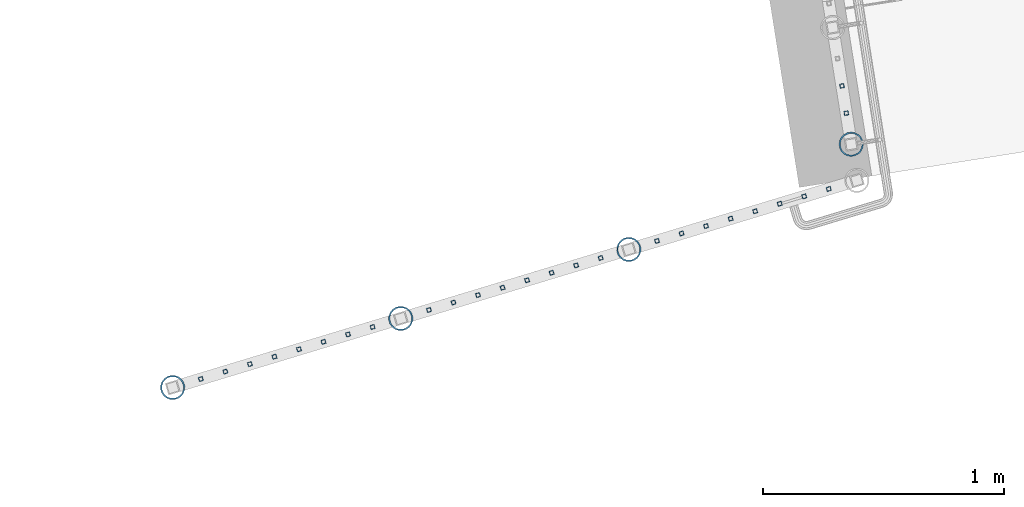
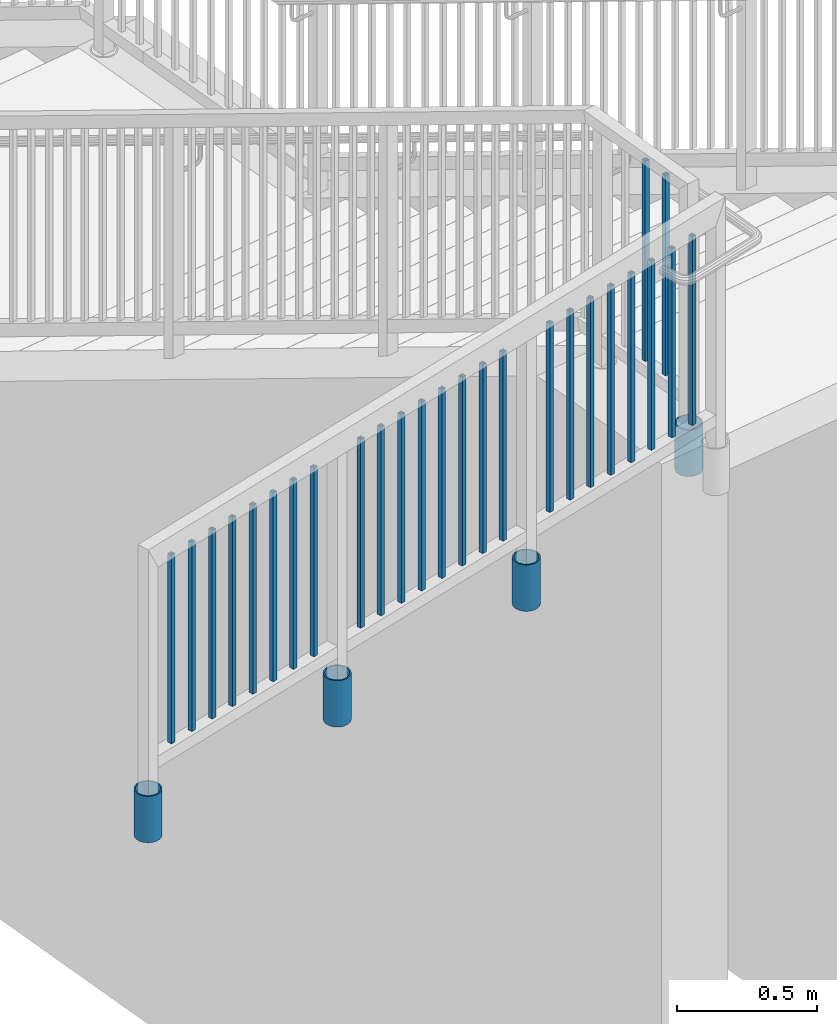
# One storey, part 209 of 975: 30 columns.
"""IFC2X3 building model written with IfcOpenShell, lengths in millimetres."""

from ifc_helpers import new_model, si_unit, frame, origin_with_axes, place, context, subcontext, project, spatial, faceted_brep, material, type_object, element, save


model = new_model("IFC2X3")

# Units and contexts
model_context = context("Model", 3, precision=1e-05, world=origin_with_axes())
body_context = subcontext(model_context, "Body", "Model", "MODEL_VIEW")
ifc_project = project(units=[si_unit("LENGTHUNIT", "METRE", prefix="MILLI"), si_unit("AREAUNIT", "SQUARE_METRE"), si_unit("VOLUMEUNIT", "CUBIC_METRE"), si_unit("MASSUNIT", "GRAM", prefix="KILO"), si_unit("TIMEUNIT", "SECOND"), si_unit("PLANEANGLEUNIT", "RADIAN"), si_unit("SOLIDANGLEUNIT", "STERADIAN"), si_unit("THERMODYNAMICTEMPERATUREUNIT", "DEGREE_CELSIUS"), si_unit("LUMINOUSINTENSITYUNIT", "LUMEN")], contexts=[model_context])

# Site, building, storey
site_placement = place(None, origin_with_axes())
site = spatial("IfcSite", under=ifc_project, at=site_placement, CompositionType="ELEMENT")
building_placement = place(site_placement, origin_with_axes())
building = spatial("IfcBuilding", under=site, at=building_placement, Name="Undefined", CompositionType="ELEMENT")
storey_placement = place(building_placement, origin_with_axes())
storey = spatial("IfcBuildingStorey", under=building, at=storey_placement, Name="Undefined", CompositionType="ELEMENT", Elevation=0.0)

# Columns
ifc_material_1 = material()
column_type_1 = type_object("IfcColumnType", Name="HSS3/4X3/4X.120_TUBES", PredefinedType="NOTDEFINED")
for number, where, z_axis, x_axis, name in (
    (1, (-1494.55040763279, 20040.1609229105, 4178.29999167089), (-0.987688340611262, -0.156434464938429, 0.0), (0.0, 0.0, 1.0), "PICKET"),
    (2, (-1512.5251867995, 20153.6491800454, 4178.29999167089), (-0.987688340611262, -0.156434464938429, 0.0), (0.0, 0.0, 1.0), "PICKET"),
):
    element("IfcColumn", number, at=place(storey_placement, frame(where, z_axis=z_axis, x_axis=x_axis)), inside=storey, type_object=column_type_1, material=ifc_material_1, Name=name, ObjectType="HSS3/4X3/4X.120_TUBES", context=body_context, shape_type="Brep", body=[
        faceted_brep([(0.0, 6.34999999998763, -6.34999999998763), (0.0, -6.35000000000582, -6.34999999998763), (876.3, -6.35000000000218, -6.3500000000131), (876.3, 6.34999999999854, -6.35000000000946), (0.0, -6.34999999998763, 6.34999999998763), (876.3, -6.34999999999854, 6.34999999999127), (0.0, 6.35000000000946, 6.34999999998763), (876.3, 6.35000000000582, 6.34999999999491), (0.0, 9.52499999997963, -9.52499999997963), (0.0, 9.52500000000873, 9.5249999999869), (876.3, 9.52500000000146, 9.52499999999418), (876.3, 9.52499999999782, -9.52500000001237), (0.0, -9.52499999997963, 9.52499999998327), (876.3, -9.52499999999782, 9.52499999999054), (0.0, -9.52500000000873, -9.5249999999869), (876.3, -9.52500000000146, -9.52500000001237)], [[[0, 1, 2, 3]], [[1, 4, 5, 2]], [[4, 6, 7, 5]], [[6, 0, 3, 7]], [[8, 9, 10, 11]], [[9, 12, 13, 10]], [[12, 14, 15, 13]], [[14, 8, 11, 15]], [[13, 15, 11, 10], [5, 7, 3, 2]], [[14, 12, 9, 8], [6, 4, 1, 0]]]),
    ])
for number, where, z_axis, x_axis, name in (
    (3, (-1567.45735962821, 19725.1939051161, 4178.29999683213), (0.957137608769341, 0.289633557930203, -1.36013231895049e-08), (0.0, 0.0, 1.0), "PICKET"),
    (4, (-1669.42828823734, 19694.3326589814, 4178.29999673016), (0.957137608769341, 0.289633557930203, -1.36013231895049e-08), (0.0, 0.0, 1.0), "PICKET"),
    (5, (-1771.39921684648, 19663.4714128468, 4178.29999662819), (0.957137608769341, 0.289633557930203, -1.36013231895049e-08), (0.0, 0.0, 1.0), "PICKET"),
    (6, (-1873.37014545561, 19632.6101667121, 4178.29999652622), (0.957137608769341, 0.289633557930203, -1.36013231895049e-08), (0.0, 0.0, 1.0), "PICKET"),
    (7, (-1975.34107406475, 19601.7489205775, 4178.29999642425), (0.957137608769341, 0.289633557930203, -1.36013231895049e-08), (0.0, 0.0, 1.0), "PICKET"),
    (8, (-2077.31200267388, 19570.8876744428, 4178.29999632228), (0.957137608769341, 0.289633557930203, -1.36013231895049e-08), (0.0, 0.0, 1.0), "PICKET"),
    (9, (-2179.28293128302, 19540.0264283082, 4178.29999622031), (0.957137608769341, 0.289633557930203, -1.36013231895049e-08), (0.0, 0.0, 1.0), "PICKET"),
    (10, (-2281.25385989215, 19509.1651821735, 4178.29999611834), (0.957137608769341, 0.289633557930203, -1.36013231895049e-08), (0.0, 0.0, 1.0), "PICKET"),
    (11, (-2515.58641139511, 19438.2450223992, 4178.30000376634), (0.957137608769341, 0.289633557930203, -1.36013231895049e-08), (0.0, 0.0, 1.0), "PICKET"),
    (12, (-2617.55734000425, 19407.3837762646, 4178.30000366437), (0.957137608769341, 0.289633557930203, -1.36013231895049e-08), (0.0, 0.0, 1.0), "PICKET"),
    (13, (-2719.52826861338, 19376.5225301299, 4178.3000035624), (0.957137608769341, 0.289633557930203, -1.36013231895049e-08), (0.0, 0.0, 1.0), "PICKET"),
    (14, (-2821.49919722252, 19345.6612839953, 4178.30000346042), (0.957137608769341, 0.289633557930203, -1.36013231895049e-08), (0.0, 0.0, 1.0), "PICKET"),
    (15, (-2923.47012583165, 19314.8000378606, 4178.30000335845), (0.957137608769341, 0.289633557930203, -1.36013231895049e-08), (0.0, 0.0, 1.0), "PICKET"),
    (16, (-3025.44105444079, 19283.938791726, 4178.30000325648), (0.957137608769341, 0.289633557930203, -1.36013231895049e-08), (0.0, 0.0, 1.0), "PICKET"),
    (17, (-3127.41198304992, 19253.0775455913, 4178.30000315451), (0.957137608769341, 0.289633557930203, -1.36013231895049e-08), (0.0, 0.0, 1.0), "PICKET"),
    (18, (-3229.38291165906, 19222.2162994567, 4178.30000305254), (0.957137608769341, 0.289633557930203, -1.36013231895049e-08), (0.0, 0.0, 1.0), "PICKET"),
    (19, (-3463.71666416523, 19151.2957762017, 4178.30001070463), (0.957137608769341, 0.289633557930203, -1.36013231895049e-08), (0.0, 0.0, 1.0), "PICKET"),
    (20, (-3565.68759277437, 19120.4345300671, 4178.30001060266), (0.957137608769341, 0.289633557930203, -1.36013231895049e-08), (0.0, 0.0, 1.0), "PICKET"),
    (21, (-3667.6585213835, 19089.5732839324, 4178.30001050068), (0.957137608769341, 0.289633557930203, -1.36013231895049e-08), (0.0, 0.0, 1.0), "PICKET"),
    (22, (-3769.62944999264, 19058.7120377978, 4178.30001039871), (0.957137608769341, 0.289633557930203, -1.36013231895049e-08), (0.0, 0.0, 1.0), "PICKET"),
    (23, (-3871.60037860177, 19027.8507916631, 4178.30001029674), (0.957137608769341, 0.289633557930203, -1.36013231895049e-08), (0.0, 0.0, 1.0), "PICKET"),
    (24, (-3973.57130721091, 18996.9895455285, 4178.30001019477), (0.957137608769341, 0.289633557930203, -1.36013231895049e-08), (0.0, 0.0, 1.0), "PICKET"),
    (25, (-4075.54223582004, 18966.1282993938, 4178.3000100928), (0.957137608769341, 0.289633557930203, -1.36013231895049e-08), (0.0, 0.0, 1.0), "PICKET"),
    (26, (-4177.51316442918, 18935.2670532592, 4178.30000999083), (0.957137608769341, 0.289633557930203, -1.36013231895049e-08), (0.0, 0.0, 1.0), "PICKET"),
):
    element("IfcColumn", number, at=place(storey_placement, frame(where, z_axis=z_axis, x_axis=x_axis)), inside=storey, type_object=column_type_1, material=ifc_material_1, Name=name, ObjectType="HSS3/4X3/4X.120_TUBES", context=body_context, shape_type="Brep", body=[
        faceted_brep([(0.0, 6.34999999998763, -6.34999999998763), (0.0, -6.35000000000582, -6.34999999998763), (825.49997943247, -6.35000000000582, -6.34999999998763), (825.49997943247, 6.34999999998763, -6.34999999998763), (0.0, -6.34999999998763, 6.34999999998763), (825.49997943247, -6.34999999998763, 6.34999999998763), (0.0, 6.35000000000946, 6.34999999998763), (825.49997943247, 6.35000000000946, 6.34999999998763), (0.0, 9.52499999997963, -9.52499999997963), (0.0, 9.52500000000873, 9.5249999999869), (825.49997943247, 9.52500000000873, 9.5249999999869), (825.49997943247, 9.52499999997963, -9.52499999997963), (0.0, -9.52499999997963, 9.52499999998327), (825.49997943247, -9.52499999997963, 9.52499999998327), (0.0, -9.52500000000873, -9.5249999999869), (825.49997943247, -9.52500000000873, -9.5249999999869)], [[[0, 1, 2, 3]], [[1, 4, 5, 2]], [[4, 6, 7, 5]], [[6, 0, 3, 7]], [[8, 9, 10, 11]], [[9, 12, 13, 10]], [[12, 14, 15, 13]], [[14, 8, 11, 15]], [[13, 15, 11, 10], [5, 7, 3, 2]], [[14, 12, 9, 8], [6, 4, 1, 0]]]),
    ])
ifc_material_2 = material(Name="STEEL/A53")
column_type_2 = type_object("IfcColumnType", Name="PIPE3-1/2STD", PredefinedType="NOTDEFINED")
column_1_placement = place(storey_placement, frame((-1474.06692255113, 19910.997122319, 3835.40003518347), z_axis=(-0.587785252279345, -0.809016994384486, -8.09014181868407e-10), x_axis=(0.0, 0.0, 1.0)))
element("IfcColumn", 27, at=column_1_placement, inside=storey, type_object=column_type_2, material=ifc_material_2, ObjectType="PIPE3-1/2STD", context=body_context, shape_type="Brep", body=[
    faceted_brep([(0.0, -45.0595999999932, 1.45519152283669e-11), (0.0, -42.8542262016344, 13.924182159768), (203.199999999991, -42.8542262017145, 13.9241821598171), (203.19999999999, -45.0596000000478, 5.82076609134674e-11), (0.0, -36.45398215971, 26.4853683542424), (203.199999999993, -36.45398215981, 26.4853683542988), (0.0, -26.4853683541623, 36.45398215979), (203.199999999995, -26.4853683542788, 36.4539821598537), (0.0, -13.9241821596988, 42.8542262017108), (203.199999999998, -13.9241821598262, 42.8542262017836), (0.0, 3.63797880709171e-11, 45.0596000000514), (203.2, -9.27684595808387e-11, 45.0596000001387), (0.0, 13.9241821597716, 42.8542262017036), (203.200000000003, 13.9241821596443, 42.8542262017927), (0.0, 26.4853683542242, 36.4539821597718), (203.200000000006, 26.4853683541096, 36.4539821598701), (0.0, 36.4539821597537, 26.4853683542206), (203.200000000008, 36.4539821596554, 26.4853683543224), (0.0, 42.8542262016563, 13.9241821597425), (203.200000000009, 42.8542262015817, 13.9241821598443), (0.0, 45.0595999999932, -1.09139364212751e-11), (203.200000000009, 45.0595999999423, 8.9130480773747e-11), (0.0, 42.8542262016344, -13.9241821597643), (203.200000000008, 42.854226201609, -13.9241821596697), (0.0, 36.45398215971, -26.4853683542387), (203.200000000007, 36.4539821597045, -26.4853683541514), (0.0, 26.4853683541623, -36.4539821597864), (203.200000000004, 26.4853683541733, -36.4539821597064), (0.0, 13.9241821596988, -42.8542262017072), (203.200000000002, 13.9241821597225, -42.8542262016381), (0.0, -3.63797880709171e-11, -45.0596000000478), (203.199999999999, -9.09494701772928e-12, -45.0595999999914), (0.0, -13.9241821597716, -42.8542262016963), (203.199999999996, -13.9241821597479, -42.8542262016472), (0.0, -26.4853683542242, -36.4539821597682), (203.199999999993, -26.4853683542133, -36.4539821597227), (0.0, -36.4539821597537, -26.4853683542169), (203.199999999992, -36.4539821597609, -26.4853683541751), (0.0, -42.8542262016563, -13.9241821597352), (203.199999999991, -42.8542262016872, -13.924182159697), (0.0, -50.799999999992, 1.81898940354586e-11), (0.0, -48.3136710278013, -15.6980633142484), (203.199999999989, -48.313671027825, -15.6980633142139), (203.199999999989, -50.8000000000466, 5.63886715099216e-11), (0.0, -41.0980633142644, -29.8594908164741), (203.19999999999, -41.0980633142663, -29.8594908164414), (0.0, -29.859490816485, -41.0980633142826), (203.199999999993, -29.8594908164687, -41.0980633142426), (0.0, -15.6980633142848, -48.313671027845), (203.199999999995, -15.6980633142539, -48.313671027794), (0.0, -4.36557456851006e-11, -50.8000000000575), (203.199999999998, -7.27595761418343e-12, -50.7999999999993), (0.0, 15.6980633142011, -48.3136710278523), (203.200000000002, 15.6980633142375, -48.3136710277831), (0.0, 29.8594908164159, -41.0980633143045), (203.200000000005, 29.8594908164378, -41.0980633142226), (0.0, 41.0980633142135, -29.8594908165032), (203.200000000008, 41.0980633142171, -29.8594908164141), (0.0, 48.3136710277722, -15.6980633142775), (203.200000000009, 48.3136710277504, -15.6980633141811), (0.0, 50.799999999992, -1.45519152283669e-11), (203.20000000001, 50.7999999999411, 9.09494701772928e-11), (0.0, 48.313671027794, 15.6980633142521), (203.20000000001, 48.3136710277213, 15.6980633143594), (0.0, 41.0980633142644, 29.8594908164814), (203.200000000008, 41.0980633141626, 29.8594908165887), (0.0, 29.859490816485, 41.0980633142863), (203.200000000007, 29.8594908163632, 41.0980633143899), (0.0, 15.6980633142848, 48.3136710278486), (203.200000000004, 15.6980633141484, 48.3136710279414), (0.0, 4.00177668780088e-11, 50.8000000000611), (203.200000000001, -9.82254277914762e-11, 50.8000000001466), (0.0, -15.6980633142011, 48.3136710278559), (203.199999999997, -15.698063314343, 48.3136710279305), (0.0, -29.8594908164159, 41.0980633143081), (203.199999999994, -29.8594908165433, 41.0980633143681), (0.0, -41.0980633142171, 29.8594908165069), (203.199999999992, -41.0980633143226, 29.8594908165596), (0.0, -48.3136710277722, 15.6980633142812), (203.19999999999, -48.3136710278559, 15.6980633143285)], [[[0, 1, 2, 3]], [[1, 4, 5, 2]], [[4, 6, 7, 5]], [[6, 8, 9, 7]], [[8, 10, 11, 9]], [[10, 12, 13, 11]], [[12, 14, 15, 13]], [[14, 16, 17, 15]], [[16, 18, 19, 17]], [[18, 20, 21, 19]], [[20, 22, 23, 21]], [[22, 24, 25, 23]], [[24, 26, 27, 25]], [[26, 28, 29, 27]], [[28, 30, 31, 29]], [[30, 32, 33, 31]], [[32, 34, 35, 33]], [[34, 36, 37, 35]], [[36, 38, 39, 37]], [[38, 0, 3, 39]], [[40, 41, 42, 43]], [[41, 44, 45, 42]], [[44, 46, 47, 45]], [[46, 48, 49, 47]], [[48, 50, 51, 49]], [[50, 52, 53, 51]], [[52, 54, 55, 53]], [[54, 56, 57, 55]], [[56, 58, 59, 57]], [[58, 60, 61, 59]], [[60, 62, 63, 61]], [[62, 64, 65, 63]], [[64, 66, 67, 65]], [[66, 68, 69, 67]], [[68, 70, 71, 69]], [[70, 72, 73, 71]], [[72, 74, 75, 73]], [[74, 76, 77, 75]], [[76, 78, 79, 77]], [[78, 40, 43, 79]], [[45, 47, 49, 51, 53, 55, 57, 59, 61, 63, 65, 67, 69, 71, 73, 75, 77, 79, 43, 42], [5, 7, 9, 11, 13, 15, 17, 19, 21, 23, 25, 27, 29, 31, 33, 35, 37, 39, 3, 2]], [[78, 76, 74, 72, 70, 68, 66, 64, 62, 60, 58, 56, 54, 52, 50, 48, 46, 44, 41, 40], [38, 36, 34, 32, 30, 28, 26, 24, 22, 20, 18, 16, 14, 12, 10, 8, 6, 4, 1, 0]]]),
])
column_2_placement = place(storey_placement, frame((-4294.69060420685, 18899.8452153737, 3835.40002182394), z_axis=(-0.881600346999202, 0.471996639999572, -8.71836346050259e-09), x_axis=(0.0, 0.0, 1.0)))
element("IfcColumn", 28, at=column_2_placement, inside=storey, type_object=column_type_2, material=ifc_material_2, ObjectType="PIPE3-1/2STD", context=body_context, shape_type="Brep", body=[
    faceted_brep([(0.0, -45.0595999999932, 1.45519152283669e-11), (0.0, -42.8542262016344, 13.924182159768), (203.199999999991, -42.8542262017145, 13.9241821598171), (203.19999999999, -45.0596000000478, 5.82076609134674e-11), (0.0, -36.45398215971, 26.4853683542424), (203.199999999993, -36.45398215981, 26.4853683542988), (0.0, -26.4853683541623, 36.45398215979), (203.199999999995, -26.4853683542788, 36.4539821598537), (0.0, -13.9241821596988, 42.8542262017108), (203.199999999998, -13.9241821598262, 42.8542262017836), (0.0, 3.63797880709171e-11, 45.0596000000514), (203.2, -9.27684595808387e-11, 45.0596000001387), (0.0, 13.9241821597716, 42.8542262017036), (203.200000000003, 13.9241821596443, 42.8542262017927), (0.0, 26.4853683542242, 36.4539821597718), (203.200000000006, 26.4853683541096, 36.4539821598701), (0.0, 36.4539821597537, 26.4853683542206), (203.200000000008, 36.4539821596554, 26.4853683543224), (0.0, 42.8542262016563, 13.9241821597425), (203.200000000009, 42.8542262015817, 13.9241821598443), (0.0, 45.0595999999932, -1.09139364212751e-11), (203.200000000009, 45.0595999999423, 8.9130480773747e-11), (0.0, 42.8542262016344, -13.9241821597643), (203.200000000008, 42.854226201609, -13.9241821596697), (0.0, 36.45398215971, -26.4853683542387), (203.200000000007, 36.4539821597045, -26.4853683541514), (0.0, 26.4853683541623, -36.4539821597864), (203.200000000004, 26.4853683541733, -36.4539821597064), (0.0, 13.9241821596988, -42.8542262017072), (203.200000000002, 13.9241821597225, -42.8542262016381), (0.0, -3.63797880709171e-11, -45.0596000000478), (203.199999999999, -9.09494701772928e-12, -45.0595999999914), (0.0, -13.9241821597716, -42.8542262016963), (203.199999999996, -13.9241821597479, -42.8542262016472), (0.0, -26.4853683542242, -36.4539821597682), (203.199999999993, -26.4853683542133, -36.4539821597227), (0.0, -36.4539821597537, -26.4853683542169), (203.199999999992, -36.4539821597609, -26.4853683541751), (0.0, -42.8542262016563, -13.9241821597352), (203.199999999991, -42.8542262016872, -13.924182159697), (0.0, -50.799999999992, 1.81898940354586e-11), (0.0, -48.3136710278013, -15.6980633142484), (203.199999999989, -48.313671027825, -15.6980633142139), (203.199999999989, -50.8000000000466, 5.63886715099216e-11), (0.0, -41.0980633142644, -29.8594908164741), (203.19999999999, -41.0980633142663, -29.8594908164414), (0.0, -29.859490816485, -41.0980633142826), (203.199999999993, -29.8594908164687, -41.0980633142426), (0.0, -15.6980633142848, -48.313671027845), (203.199999999995, -15.6980633142539, -48.313671027794), (0.0, -4.36557456851006e-11, -50.8000000000575), (203.199999999998, -7.27595761418343e-12, -50.7999999999993), (0.0, 15.6980633142011, -48.3136710278523), (203.200000000002, 15.6980633142375, -48.3136710277831), (0.0, 29.8594908164159, -41.0980633143045), (203.200000000005, 29.8594908164378, -41.0980633142226), (0.0, 41.0980633142135, -29.8594908165032), (203.200000000008, 41.0980633142171, -29.8594908164141), (0.0, 48.3136710277722, -15.6980633142775), (203.200000000009, 48.3136710277504, -15.6980633141811), (0.0, 50.799999999992, -1.45519152283669e-11), (203.20000000001, 50.7999999999411, 9.09494701772928e-11), (0.0, 48.313671027794, 15.6980633142521), (203.20000000001, 48.3136710277213, 15.6980633143594), (0.0, 41.0980633142644, 29.8594908164814), (203.200000000008, 41.0980633141626, 29.8594908165887), (0.0, 29.859490816485, 41.0980633142863), (203.200000000007, 29.8594908163632, 41.0980633143899), (0.0, 15.6980633142848, 48.3136710278486), (203.200000000004, 15.6980633141484, 48.3136710279414), (0.0, 4.00177668780088e-11, 50.8000000000611), (203.200000000001, -9.82254277914762e-11, 50.8000000001466), (0.0, -15.6980633142011, 48.3136710278559), (203.199999999997, -15.698063314343, 48.3136710279305), (0.0, -29.8594908164159, 41.0980633143081), (203.199999999994, -29.8594908165433, 41.0980633143681), (0.0, -41.0980633142171, 29.8594908165069), (203.199999999992, -41.0980633143226, 29.8594908165596), (0.0, -48.3136710277722, 15.6980633142812), (203.19999999999, -48.3136710278559, 15.6980633143285)], [[[0, 1, 2, 3]], [[1, 4, 5, 2]], [[4, 6, 7, 5]], [[6, 8, 9, 7]], [[8, 10, 11, 9]], [[10, 12, 13, 11]], [[12, 14, 15, 13]], [[14, 16, 17, 15]], [[16, 18, 19, 17]], [[18, 20, 21, 19]], [[20, 22, 23, 21]], [[22, 24, 25, 23]], [[24, 26, 27, 25]], [[26, 28, 29, 27]], [[28, 30, 31, 29]], [[30, 32, 33, 31]], [[32, 34, 35, 33]], [[34, 36, 37, 35]], [[36, 38, 39, 37]], [[38, 0, 3, 39]], [[40, 41, 42, 43]], [[41, 44, 45, 42]], [[44, 46, 47, 45]], [[46, 48, 49, 47]], [[48, 50, 51, 49]], [[50, 52, 53, 51]], [[52, 54, 55, 53]], [[54, 56, 57, 55]], [[56, 58, 59, 57]], [[58, 60, 61, 59]], [[60, 62, 63, 61]], [[62, 64, 65, 63]], [[64, 66, 67, 65]], [[66, 68, 69, 67]], [[68, 70, 71, 69]], [[70, 72, 73, 71]], [[72, 74, 75, 73]], [[74, 76, 77, 75]], [[76, 78, 79, 77]], [[78, 40, 43, 79]], [[45, 47, 49, 51, 53, 55, 57, 59, 61, 63, 65, 67, 69, 71, 73, 75, 77, 79, 43, 42], [5, 7, 9, 11, 13, 15, 17, 19, 21, 23, 25, 27, 29, 31, 33, 35, 37, 39, 3, 2]], [[78, 76, 74, 72, 70, 68, 66, 64, 62, 60, 58, 56, 54, 52, 50, 48, 46, 44, 41, 40], [38, 36, 34, 32, 30, 28, 26, 24, 22, 20, 18, 16, 14, 12, 10, 8, 6, 4, 1, 0]]]),
])
column_3_placement = place(storey_placement, frame((-3346.54068504426, 19186.7251494806, 3835.40001593121), z_axis=(-0.881600346999202, 0.471996639999572, -8.71836346050259e-09), x_axis=(0.0, 0.0, 1.0)))
element("IfcColumn", 29, at=column_3_placement, inside=storey, type_object=column_type_2, material=ifc_material_2, ObjectType="PIPE3-1/2STD", context=body_context, shape_type="Brep", body=[
    faceted_brep([(0.0, -45.0595999999932, 1.45519152283669e-11), (0.0, -42.8542262016344, 13.924182159768), (203.199999999991, -42.8542262017145, 13.9241821598171), (203.19999999999, -45.0596000000478, 5.82076609134674e-11), (0.0, -36.45398215971, 26.4853683542424), (203.199999999993, -36.45398215981, 26.4853683542988), (0.0, -26.4853683541623, 36.45398215979), (203.199999999995, -26.4853683542788, 36.4539821598537), (0.0, -13.9241821596988, 42.8542262017108), (203.199999999998, -13.9241821598262, 42.8542262017836), (0.0, 3.63797880709171e-11, 45.0596000000514), (203.2, -9.27684595808387e-11, 45.0596000001387), (0.0, 13.9241821597716, 42.8542262017036), (203.200000000003, 13.9241821596443, 42.8542262017927), (0.0, 26.4853683542242, 36.4539821597718), (203.200000000006, 26.4853683541096, 36.4539821598701), (0.0, 36.4539821597537, 26.4853683542206), (203.200000000008, 36.4539821596554, 26.4853683543224), (0.0, 42.8542262016563, 13.9241821597425), (203.200000000009, 42.8542262015817, 13.9241821598443), (0.0, 45.0595999999932, -1.09139364212751e-11), (203.200000000009, 45.0595999999423, 8.9130480773747e-11), (0.0, 42.8542262016344, -13.9241821597643), (203.200000000008, 42.854226201609, -13.9241821596697), (0.0, 36.45398215971, -26.4853683542387), (203.200000000007, 36.4539821597045, -26.4853683541514), (0.0, 26.4853683541623, -36.4539821597864), (203.200000000004, 26.4853683541733, -36.4539821597064), (0.0, 13.9241821596988, -42.8542262017072), (203.200000000002, 13.9241821597225, -42.8542262016381), (0.0, -3.63797880709171e-11, -45.0596000000478), (203.199999999999, -9.09494701772928e-12, -45.0595999999914), (0.0, -13.9241821597716, -42.8542262016963), (203.199999999996, -13.9241821597479, -42.8542262016472), (0.0, -26.4853683542242, -36.4539821597682), (203.199999999993, -26.4853683542133, -36.4539821597227), (0.0, -36.4539821597537, -26.4853683542169), (203.199999999992, -36.4539821597609, -26.4853683541751), (0.0, -42.8542262016563, -13.9241821597352), (203.199999999991, -42.8542262016872, -13.924182159697), (0.0, -50.799999999992, 1.81898940354586e-11), (0.0, -48.3136710278013, -15.6980633142484), (203.199999999989, -48.313671027825, -15.6980633142139), (203.199999999989, -50.8000000000466, 5.63886715099216e-11), (0.0, -41.0980633142644, -29.8594908164741), (203.19999999999, -41.0980633142663, -29.8594908164414), (0.0, -29.859490816485, -41.0980633142826), (203.199999999993, -29.8594908164687, -41.0980633142426), (0.0, -15.6980633142848, -48.313671027845), (203.199999999995, -15.6980633142539, -48.313671027794), (0.0, -4.36557456851006e-11, -50.8000000000575), (203.199999999998, -7.27595761418343e-12, -50.7999999999993), (0.0, 15.6980633142011, -48.3136710278523), (203.200000000002, 15.6980633142375, -48.3136710277831), (0.0, 29.8594908164159, -41.0980633143045), (203.200000000005, 29.8594908164378, -41.0980633142226), (0.0, 41.0980633142135, -29.8594908165032), (203.200000000008, 41.0980633142171, -29.8594908164141), (0.0, 48.3136710277722, -15.6980633142775), (203.200000000009, 48.3136710277504, -15.6980633141811), (0.0, 50.799999999992, -1.45519152283669e-11), (203.20000000001, 50.7999999999411, 9.09494701772928e-11), (0.0, 48.313671027794, 15.6980633142521), (203.20000000001, 48.3136710277213, 15.6980633143594), (0.0, 41.0980633142644, 29.8594908164814), (203.200000000008, 41.0980633141626, 29.8594908165887), (0.0, 29.859490816485, 41.0980633142863), (203.200000000007, 29.8594908163632, 41.0980633143899), (0.0, 15.6980633142848, 48.3136710278486), (203.200000000004, 15.6980633141484, 48.3136710279414), (0.0, 4.00177668780088e-11, 50.8000000000611), (203.200000000001, -9.82254277914762e-11, 50.8000000001466), (0.0, -15.6980633142011, 48.3136710278559), (203.199999999997, -15.698063314343, 48.3136710279305), (0.0, -29.8594908164159, 41.0980633143081), (203.199999999994, -29.8594908165433, 41.0980633143681), (0.0, -41.0980633142171, 29.8594908165069), (203.199999999992, -41.0980633143226, 29.8594908165596), (0.0, -48.3136710277722, 15.6980633142812), (203.19999999999, -48.3136710278559, 15.6980633143285)], [[[0, 1, 2, 3]], [[1, 4, 5, 2]], [[4, 6, 7, 5]], [[6, 8, 9, 7]], [[8, 10, 11, 9]], [[10, 12, 13, 11]], [[12, 14, 15, 13]], [[14, 16, 17, 15]], [[16, 18, 19, 17]], [[18, 20, 21, 19]], [[20, 22, 23, 21]], [[22, 24, 25, 23]], [[24, 26, 27, 25]], [[26, 28, 29, 27]], [[28, 30, 31, 29]], [[30, 32, 33, 31]], [[32, 34, 35, 33]], [[34, 36, 37, 35]], [[36, 38, 39, 37]], [[38, 0, 3, 39]], [[40, 41, 42, 43]], [[41, 44, 45, 42]], [[44, 46, 47, 45]], [[46, 48, 49, 47]], [[48, 50, 51, 49]], [[50, 52, 53, 51]], [[52, 54, 55, 53]], [[54, 56, 57, 55]], [[56, 58, 59, 57]], [[58, 60, 61, 59]], [[60, 62, 63, 61]], [[62, 64, 65, 63]], [[64, 66, 67, 65]], [[66, 68, 69, 67]], [[68, 70, 71, 69]], [[70, 72, 73, 71]], [[72, 74, 75, 73]], [[74, 76, 77, 75]], [[76, 78, 79, 77]], [[78, 40, 43, 79]], [[45, 47, 49, 51, 53, 55, 57, 59, 61, 63, 65, 67, 69, 71, 73, 75, 77, 79, 43, 42], [5, 7, 9, 11, 13, 15, 17, 19, 21, 23, 25, 27, 29, 31, 33, 35, 37, 39, 3, 2]], [[78, 76, 74, 72, 70, 68, 66, 64, 62, 60, 58, 56, 54, 52, 50, 48, 46, 44, 41, 40], [38, 36, 34, 32, 30, 28, 26, 24, 22, 20, 18, 16, 14, 12, 10, 8, 6, 4, 1, 0]]]),
])
column_4_placement = place(storey_placement, frame((-2398.41163327645, 19473.6740321977, 3835.40001692181), z_axis=(-0.881600346999202, 0.471996639999572, -8.71836346050259e-09), x_axis=(0.0, 0.0, 1.0)))
element("IfcColumn", 30, at=column_4_placement, inside=storey, type_object=column_type_2, material=ifc_material_2, ObjectType="PIPE3-1/2STD", context=body_context, shape_type="Brep", body=[
    faceted_brep([(0.0, -45.0595999999932, 1.45519152283669e-11), (0.0, -42.8542262016344, 13.924182159768), (203.199999999991, -42.8542262017145, 13.9241821598171), (203.19999999999, -45.0596000000478, 5.82076609134674e-11), (0.0, -36.45398215971, 26.4853683542424), (203.199999999993, -36.45398215981, 26.4853683542988), (0.0, -26.4853683541623, 36.45398215979), (203.199999999995, -26.4853683542788, 36.4539821598537), (0.0, -13.9241821596988, 42.8542262017108), (203.199999999998, -13.9241821598262, 42.8542262017836), (0.0, 3.63797880709171e-11, 45.0596000000514), (203.2, -9.27684595808387e-11, 45.0596000001387), (0.0, 13.9241821597716, 42.8542262017036), (203.200000000003, 13.9241821596443, 42.8542262017927), (0.0, 26.4853683542242, 36.4539821597718), (203.200000000006, 26.4853683541096, 36.4539821598701), (0.0, 36.4539821597537, 26.4853683542206), (203.200000000008, 36.4539821596554, 26.4853683543224), (0.0, 42.8542262016563, 13.9241821597425), (203.200000000009, 42.8542262015817, 13.9241821598443), (0.0, 45.0595999999932, -1.09139364212751e-11), (203.200000000009, 45.0595999999423, 8.9130480773747e-11), (0.0, 42.8542262016344, -13.9241821597643), (203.200000000008, 42.854226201609, -13.9241821596697), (0.0, 36.45398215971, -26.4853683542387), (203.200000000007, 36.4539821597045, -26.4853683541514), (0.0, 26.4853683541623, -36.4539821597864), (203.200000000004, 26.4853683541733, -36.4539821597064), (0.0, 13.9241821596988, -42.8542262017072), (203.200000000002, 13.9241821597225, -42.8542262016381), (0.0, -3.63797880709171e-11, -45.0596000000478), (203.199999999999, -9.09494701772928e-12, -45.0595999999914), (0.0, -13.9241821597716, -42.8542262016963), (203.199999999996, -13.9241821597479, -42.8542262016472), (0.0, -26.4853683542242, -36.4539821597682), (203.199999999993, -26.4853683542133, -36.4539821597227), (0.0, -36.4539821597537, -26.4853683542169), (203.199999999992, -36.4539821597609, -26.4853683541751), (0.0, -42.8542262016563, -13.9241821597352), (203.199999999991, -42.8542262016872, -13.924182159697), (0.0, -50.799999999992, 1.81898940354586e-11), (0.0, -48.3136710278013, -15.6980633142484), (203.199999999989, -48.313671027825, -15.6980633142139), (203.199999999989, -50.8000000000466, 5.63886715099216e-11), (0.0, -41.0980633142644, -29.8594908164741), (203.19999999999, -41.0980633142663, -29.8594908164414), (0.0, -29.859490816485, -41.0980633142826), (203.199999999993, -29.8594908164687, -41.0980633142426), (0.0, -15.6980633142848, -48.313671027845), (203.199999999995, -15.6980633142539, -48.313671027794), (0.0, -4.36557456851006e-11, -50.8000000000575), (203.199999999998, -7.27595761418343e-12, -50.7999999999993), (0.0, 15.6980633142011, -48.3136710278523), (203.200000000002, 15.6980633142375, -48.3136710277831), (0.0, 29.8594908164159, -41.0980633143045), (203.200000000005, 29.8594908164378, -41.0980633142226), (0.0, 41.0980633142135, -29.8594908165032), (203.200000000008, 41.0980633142171, -29.8594908164141), (0.0, 48.3136710277722, -15.6980633142775), (203.200000000009, 48.3136710277504, -15.6980633141811), (0.0, 50.799999999992, -1.45519152283669e-11), (203.20000000001, 50.7999999999411, 9.09494701772928e-11), (0.0, 48.313671027794, 15.6980633142521), (203.20000000001, 48.3136710277213, 15.6980633143594), (0.0, 41.0980633142644, 29.8594908164814), (203.200000000008, 41.0980633141626, 29.8594908165887), (0.0, 29.859490816485, 41.0980633142863), (203.200000000007, 29.8594908163632, 41.0980633143899), (0.0, 15.6980633142848, 48.3136710278486), (203.200000000004, 15.6980633141484, 48.3136710279414), (0.0, 4.00177668780088e-11, 50.8000000000611), (203.200000000001, -9.82254277914762e-11, 50.8000000001466), (0.0, -15.6980633142011, 48.3136710278559), (203.199999999997, -15.698063314343, 48.3136710279305), (0.0, -29.8594908164159, 41.0980633143081), (203.199999999994, -29.8594908165433, 41.0980633143681), (0.0, -41.0980633142171, 29.8594908165069), (203.199999999992, -41.0980633143226, 29.8594908165596), (0.0, -48.3136710277722, 15.6980633142812), (203.19999999999, -48.3136710278559, 15.6980633143285)], [[[0, 1, 2, 3]], [[1, 4, 5, 2]], [[4, 6, 7, 5]], [[6, 8, 9, 7]], [[8, 10, 11, 9]], [[10, 12, 13, 11]], [[12, 14, 15, 13]], [[14, 16, 17, 15]], [[16, 18, 19, 17]], [[18, 20, 21, 19]], [[20, 22, 23, 21]], [[22, 24, 25, 23]], [[24, 26, 27, 25]], [[26, 28, 29, 27]], [[28, 30, 31, 29]], [[30, 32, 33, 31]], [[32, 34, 35, 33]], [[34, 36, 37, 35]], [[36, 38, 39, 37]], [[38, 0, 3, 39]], [[40, 41, 42, 43]], [[41, 44, 45, 42]], [[44, 46, 47, 45]], [[46, 48, 49, 47]], [[48, 50, 51, 49]], [[50, 52, 53, 51]], [[52, 54, 55, 53]], [[54, 56, 57, 55]], [[56, 58, 59, 57]], [[58, 60, 61, 59]], [[60, 62, 63, 61]], [[62, 64, 65, 63]], [[64, 66, 67, 65]], [[66, 68, 69, 67]], [[68, 70, 71, 69]], [[70, 72, 73, 71]], [[72, 74, 75, 73]], [[74, 76, 77, 75]], [[76, 78, 79, 77]], [[78, 40, 43, 79]], [[45, 47, 49, 51, 53, 55, 57, 59, 61, 63, 65, 67, 69, 71, 73, 75, 77, 79, 43, 42], [5, 7, 9, 11, 13, 15, 17, 19, 21, 23, 25, 27, 29, 31, 33, 35, 37, 39, 3, 2]], [[78, 76, 74, 72, 70, 68, 66, 64, 62, 60, 58, 56, 54, 52, 50, 48, 46, 44, 41, 40], [38, 36, 34, 32, 30, 28, 26, 24, 22, 20, 18, 16, 14, 12, 10, 8, 6, 4, 1, 0]]]),
])

save(model, "model.ifc")
